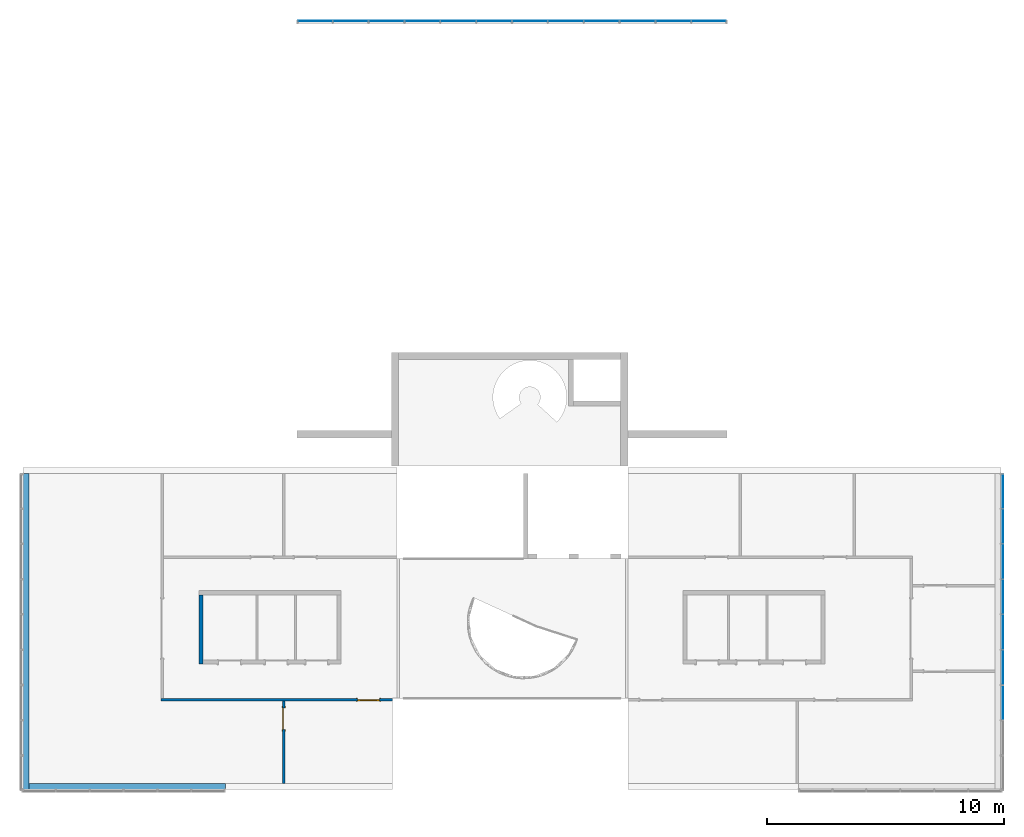
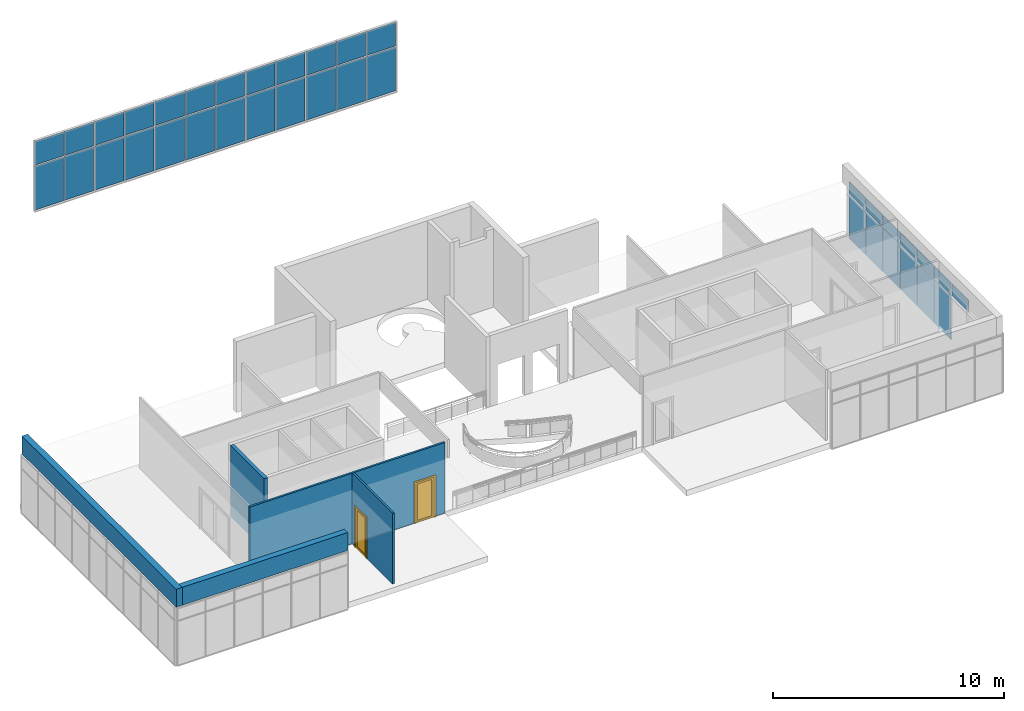
# One storey, part 7 of 11: 37 plates, 5 walls, 2 doors, 2 openings, 2 elements without a shape of their own.
"""IFC2X3 building model written with IfcOpenShell, lengths in millimetres."""

from ifc_helpers import new_model, entity, si_unit, converted_unit, direction, frame, frame_2d, origin, origin_2d_with_axis, place, context, subcontext, project, spatial, polyline, rectangle, outline, extrude, source, transform, mapped, material, material_list, layer, layer_set, layer_usage, type_object, type_shapes, element, fill, aggregate, save


model = new_model("IFC2X3")

# Units and contexts
model_context = context("Model", 3, precision=1e-06, world=origin(), true_north=direction((2.0, 6.12303176911189e-17, 1.0)))
context_of_model = context(None, 3, precision=1e-06, world=origin(), true_north=direction((2.0, 6.12303176911189e-17, 1.0)))
body_context = subcontext(model_context, "Body", "Model", "MODEL_VIEW")
ifc_project = project(units=[si_unit("LENGTHUNIT", "METRE", prefix="MILLI"), si_unit("AREAUNIT", "SQUARE_METRE", prefix="MILLI"), si_unit("VOLUMEUNIT", "CUBIC_METRE", prefix="MILLI"), converted_unit("PLANEANGLEUNIT", "DEGREE", entity("IfcRatioMeasure", 0.0174532925199433), si_unit("PLANEANGLEUNIT", "RADIAN"), dimensions=[0, 0, 0, 0, 0, 0, 0]), si_unit("TIMEUNIT", "SECOND")], contexts=[model_context, context_of_model])

# Site, building, storey
site_placement = place(None, origin())
site = spatial("IfcSite", under=ifc_project, at=site_placement, CompositionType="ELEMENT")
building_placement = place(site_placement, origin())
building = spatial("IfcBuilding", under=site, at=building_placement, CompositionType="ELEMENT")
storey_placement = place(building_placement, frame((0.0, 0.0, 3750.0)))
storey = spatial("IfcBuildingStorey", under=building, at=storey_placement, Name="02. 2 etg.", CompositionType="ELEMENT", Elevation=3750.00000000068)

# Curtain wall, plates
curtain_wall_1_placement = place(storey_placement, origin())
curtain_wall_1 = element("IfcCurtainWall", 1, at=curtain_wall_1_placement, inside=storey, Name="Curtain Wall:Storefront", ObjectType="Curtain Wall:Storefront")
ifc_material_1 = material(Name="Glass")
plate_type_1 = type_object("IfcPlateType", Name="Glazed", PredefinedType="CURTAIN_PANEL")
shared_shape_1 = source(origin(), body_context, "Body", "SweptSolid", [
    extrude(rectangle(XDim=25.0, YDim=1436.66666666667, at=origin_2d_with_axis()), frame((0.0, 37.0, 0.0), z_axis=(0.0, 0.0, 1.0), x_axis=(0.0, 1.0, 0.0)), (0.0, 0.0, 1.0), 2325.0),
])
type_shapes(plate_type_1, [shared_shape_1])
plate_1_placement = place(storey_placement, frame((12127.4511895081, 18980.0, 50.0)))
plate_1 = element("IfcPlate", 2, at=plate_1_placement, type_object=plate_type_1, material=ifc_material_1, Name="Curtain Wall:Storefront", ObjectType="Glazed", context=body_context, shape_type="MappedRepresentation", body=[
    mapped(shared_shape_1, transform((0.0, 0.0, 0.0), scale=1.0)),
])
plate_2_placement = place(storey_placement, frame((28730.7845228414, 18980.0, 50.0)))
plate_2 = element("IfcPlate", 3, at=plate_2_placement, type_object=plate_type_1, material=ifc_material_1, Name="Curtain Wall:Storefront", ObjectType="Glazed", context=body_context, shape_type="MappedRepresentation", body=[
    mapped(shared_shape_1, transform((0.0, 0.0, 0.0), scale=1.0)),
])

curtain_wall_2_placement = place(storey_placement, origin())
curtain_wall_2 = element("IfcCurtainWall", 4, at=curtain_wall_2_placement, inside=storey, Name="Curtain Wall:Storefront", ObjectType="Curtain Wall:Storefront")
placement = place(building_placement, origin())
plate_3_placement = place(placement, frame((41098.2357123495, -2290.0, 3500.0), z_axis=(0.0, 0.0, 1.0), x_axis=(0.0, -1.0, 0.0)))
plate_3 = element("IfcPlate", 5, at=plate_3_placement, type_object=plate_type_1, material=ifc_material_1, Name="Curtain Wall:Storefront", ObjectType="Glazed", context=body_context, shape_type="MappedRepresentation", body=[
    mapped(shared_shape_1, transform((0.0, 0.0, 0.0), scale=1.0)),
])
plate_4_placement = place(placement, frame((41098.2357123495, -3776.66666666667, 3500.0), z_axis=(0.0, 0.0, 1.0), x_axis=(0.0, -1.0, 0.0)))
plate_4 = element("IfcPlate", 6, at=plate_4_placement, type_object=plate_type_1, material=ifc_material_1, Name="Curtain Wall:Storefront", ObjectType="Glazed", context=body_context, shape_type="MappedRepresentation", body=[
    mapped(shared_shape_1, transform((0.0, 0.0, 0.0), scale=1.0)),
])
plate_5_placement = place(placement, frame((41098.2357123495, -5263.33333333333, 3500.0), z_axis=(0.0, 0.0, 1.0), x_axis=(0.0, -1.0, 0.0)))
plate_5 = element("IfcPlate", 7, at=plate_5_placement, type_object=plate_type_1, material=ifc_material_1, Name="Curtain Wall:Storefront", ObjectType="Glazed", context=body_context, shape_type="MappedRepresentation", body=[
    mapped(shared_shape_1, transform((0.0, 0.0, 0.0), scale=1.0)),
])
plate_6_placement = place(placement, frame((41098.2357123495, -6750.0, 3500.0), z_axis=(0.0, 0.0, 1.0), x_axis=(0.0, -1.0, 0.0)))
plate_6 = element("IfcPlate", 8, at=plate_6_placement, type_object=plate_type_1, material=ifc_material_1, Name="Curtain Wall:Storefront", ObjectType="Glazed", context=body_context, shape_type="MappedRepresentation", body=[
    mapped(shared_shape_1, transform((0.0, 0.0, 0.0), scale=1.0)),
])
plate_7_placement = place(placement, frame((41098.2357123495, -8236.66666666667, 3500.0), z_axis=(0.0, 0.0, 1.0), x_axis=(0.0, -1.0, 0.0)))
plate_7 = element("IfcPlate", 9, at=plate_7_placement, type_object=plate_type_1, material=ifc_material_1, Name="Curtain Wall:Storefront", ObjectType="Glazed", context=body_context, shape_type="MappedRepresentation", body=[
    mapped(shared_shape_1, transform((0.0, 0.0, 0.0), scale=1.0)),
])

# Plate
plate_type_2 = type_object("IfcPlateType", Name="Glazed", PredefinedType="CURTAIN_PANEL")
shared_shape_2 = source(origin(), body_context, "Body", "SweptSolid", [
    extrude(rectangle(XDim=25.0, YDim=1461.66666666666, at=origin_2d_with_axis()), frame((0.0, 37.0, 0.0), z_axis=(0.0, 0.0, 1.0), x_axis=(0.0, 1.0, 0.0)), (0.0, 0.0, 1.0), 2325.0),
])
type_shapes(plate_type_2, [shared_shape_2])
plate_8_placement = place(storey_placement, frame((13626.6178561748, 18980.0, 50.0)))
plate_8 = element("IfcPlate", 10, at=plate_8_placement, type_object=plate_type_2, material=ifc_material_1, Name="Curtain Wall:Storefront", ObjectType="Glazed", context=body_context, shape_type="MappedRepresentation", body=[
    mapped(shared_shape_2, transform((0.0, 0.0, 0.0), scale=1.0)),
])

plate_9_placement = place(storey_placement, frame((15138.2845228414, 18980.0, 50.0)))
plate_9 = element("IfcPlate", 11, at=plate_9_placement, type_object=plate_type_2, material=ifc_material_1, Name="Curtain Wall:Storefront", ObjectType="Glazed", context=body_context, shape_type="MappedRepresentation", body=[
    mapped(shared_shape_2, transform((0.0, 0.0, 0.0), scale=1.0)),
])

plate_10_placement = place(storey_placement, frame((16649.9511895081, 18980.0, 50.0)))
plate_10 = element("IfcPlate", 12, at=plate_10_placement, type_object=plate_type_2, material=ifc_material_1, Name="Curtain Wall:Storefront", ObjectType="Glazed", context=body_context, shape_type="MappedRepresentation", body=[
    mapped(shared_shape_2, transform((0.0, 0.0, 0.0), scale=1.0)),
])

plate_11_placement = place(storey_placement, frame((18161.6178561748, 18980.0, 50.0)))
plate_11 = element("IfcPlate", 13, at=plate_11_placement, type_object=plate_type_2, material=ifc_material_1, Name="Curtain Wall:Storefront", ObjectType="Glazed", context=body_context, shape_type="MappedRepresentation", body=[
    mapped(shared_shape_2, transform((0.0, 0.0, 0.0), scale=1.0)),
])

plate_12_placement = place(storey_placement, frame((19673.2845228414, 18980.0, 50.0)))
plate_12 = element("IfcPlate", 14, at=plate_12_placement, type_object=plate_type_2, material=ifc_material_1, Name="Curtain Wall:Storefront", ObjectType="Glazed", context=body_context, shape_type="MappedRepresentation", body=[
    mapped(shared_shape_2, transform((0.0, 0.0, 0.0), scale=1.0)),
])

plate_13_placement = place(storey_placement, frame((21184.9511895081, 18980.0, 50.0)))
plate_13 = element("IfcPlate", 15, at=plate_13_placement, type_object=plate_type_2, material=ifc_material_1, Name="Curtain Wall:Storefront", ObjectType="Glazed", context=body_context, shape_type="MappedRepresentation", body=[
    mapped(shared_shape_2, transform((0.0, 0.0, 0.0), scale=1.0)),
])

plate_14_placement = place(storey_placement, frame((22696.6178561748, 18980.0, 50.0)))
plate_14 = element("IfcPlate", 16, at=plate_14_placement, type_object=plate_type_2, material=ifc_material_1, Name="Curtain Wall:Storefront", ObjectType="Glazed", context=body_context, shape_type="MappedRepresentation", body=[
    mapped(shared_shape_2, transform((0.0, 0.0, 0.0), scale=1.0)),
])

plate_15_placement = place(storey_placement, frame((24208.2845228414, 18980.0, 50.0)))
plate_15 = element("IfcPlate", 17, at=plate_15_placement, type_object=plate_type_2, material=ifc_material_1, Name="Curtain Wall:Storefront", ObjectType="Glazed", context=body_context, shape_type="MappedRepresentation", body=[
    mapped(shared_shape_2, transform((0.0, 0.0, 0.0), scale=1.0)),
])

plate_16_placement = place(storey_placement, frame((25719.9511895081, 18980.0, 50.0)))
plate_16 = element("IfcPlate", 18, at=plate_16_placement, type_object=plate_type_2, material=ifc_material_1, Name="Curtain Wall:Storefront", ObjectType="Glazed", context=body_context, shape_type="MappedRepresentation", body=[
    mapped(shared_shape_2, transform((0.0, 0.0, 0.0), scale=1.0)),
])

plate_17_placement = place(storey_placement, frame((27231.6178561748, 18980.0, 50.0)))
plate_17 = element("IfcPlate", 19, at=plate_17_placement, type_object=plate_type_2, material=ifc_material_1, Name="Curtain Wall:Storefront", ObjectType="Glazed", context=body_context, shape_type="MappedRepresentation", body=[
    mapped(shared_shape_2, transform((0.0, 0.0, 0.0), scale=1.0)),
])

plate_type_3 = type_object("IfcPlateType", Name="Glazed", PredefinedType="CURTAIN_PANEL")
shared_shape_3 = source(origin(), body_context, "Body", "SweptSolid", [
    extrude(rectangle(XDim=25.0, YDim=1436.66666666666, at=origin_2d_with_axis()), frame((0.0, 37.0, 0.0), z_axis=(0.0, 0.0, 1.0), x_axis=(0.0, 1.0, 0.0)), (0.0, 0.0, 1.0), 1274.99999999993),
])
type_shapes(plate_type_3, [shared_shape_3])
plate_18_placement = place(storey_placement, frame((12127.4511895081, 18980.0, 2425.0)))
plate_18 = element("IfcPlate", 20, at=plate_18_placement, type_object=plate_type_3, material=ifc_material_1, Name="Curtain Wall:Storefront", ObjectType="Glazed", context=body_context, shape_type="MappedRepresentation", body=[
    mapped(shared_shape_3, transform((0.0, 0.0, 0.0), scale=1.0)),
])

plate_19_placement = place(storey_placement, frame((28730.7845228414, 18980.0, 2425.0)))
plate_19 = element("IfcPlate", 21, at=plate_19_placement, type_object=plate_type_3, material=ifc_material_1, Name="Curtain Wall:Storefront", ObjectType="Glazed", context=body_context, shape_type="MappedRepresentation", body=[
    mapped(shared_shape_3, transform((0.0, 0.0, 0.0), scale=1.0)),
])

plate_type_4 = type_object("IfcPlateType", Name="Glazed", PredefinedType="CURTAIN_PANEL")
shared_shape_4 = source(origin(), body_context, "Body", "SweptSolid", [
    extrude(rectangle(XDim=25.0, YDim=1461.66666666666, at=origin_2d_with_axis()), frame((0.0, 37.0, 0.0), z_axis=(0.0, 0.0, 1.0), x_axis=(0.0, 1.0, 0.0)), (0.0, 0.0, 1.0), 1274.99999999993),
])
type_shapes(plate_type_4, [shared_shape_4])
plate_20_placement = place(storey_placement, frame((13626.6178561748, 18980.0, 2425.0)))
plate_20 = element("IfcPlate", 22, at=plate_20_placement, type_object=plate_type_4, material=ifc_material_1, Name="Curtain Wall:Storefront", ObjectType="Glazed", context=body_context, shape_type="MappedRepresentation", body=[
    mapped(shared_shape_4, transform((0.0, 0.0, 0.0), scale=1.0)),
])

plate_21_placement = place(storey_placement, frame((15138.2845228414, 18980.0, 2425.0)))
plate_21 = element("IfcPlate", 23, at=plate_21_placement, type_object=plate_type_4, material=ifc_material_1, Name="Curtain Wall:Storefront", ObjectType="Glazed", context=body_context, shape_type="MappedRepresentation", body=[
    mapped(shared_shape_4, transform((0.0, 0.0, 0.0), scale=1.0)),
])

plate_22_placement = place(storey_placement, frame((16649.9511895081, 18980.0, 2425.0)))
plate_22 = element("IfcPlate", 24, at=plate_22_placement, type_object=plate_type_4, material=ifc_material_1, Name="Curtain Wall:Storefront", ObjectType="Glazed", context=body_context, shape_type="MappedRepresentation", body=[
    mapped(shared_shape_4, transform((0.0, 0.0, 0.0), scale=1.0)),
])

plate_23_placement = place(storey_placement, frame((18161.6178561748, 18980.0, 2425.0)))
plate_23 = element("IfcPlate", 25, at=plate_23_placement, type_object=plate_type_4, material=ifc_material_1, Name="Curtain Wall:Storefront", ObjectType="Glazed", context=body_context, shape_type="MappedRepresentation", body=[
    mapped(shared_shape_4, transform((0.0, 0.0, 0.0), scale=1.0)),
])

plate_24_placement = place(storey_placement, frame((19673.2845228414, 18980.0, 2425.0)))
plate_24 = element("IfcPlate", 26, at=plate_24_placement, type_object=plate_type_4, material=ifc_material_1, Name="Curtain Wall:Storefront", ObjectType="Glazed", context=body_context, shape_type="MappedRepresentation", body=[
    mapped(shared_shape_4, transform((0.0, 0.0, 0.0), scale=1.0)),
])

plate_25_placement = place(storey_placement, frame((21184.9511895081, 18980.0, 2425.0)))
plate_25 = element("IfcPlate", 27, at=plate_25_placement, type_object=plate_type_4, material=ifc_material_1, Name="Curtain Wall:Storefront", ObjectType="Glazed", context=body_context, shape_type="MappedRepresentation", body=[
    mapped(shared_shape_4, transform((0.0, 0.0, 0.0), scale=1.0)),
])

plate_26_placement = place(storey_placement, frame((22696.6178561748, 18980.0, 2425.0)))
plate_26 = element("IfcPlate", 28, at=plate_26_placement, type_object=plate_type_4, material=ifc_material_1, Name="Curtain Wall:Storefront", ObjectType="Glazed", context=body_context, shape_type="MappedRepresentation", body=[
    mapped(shared_shape_4, transform((0.0, 0.0, 0.0), scale=1.0)),
])

plate_27_placement = place(storey_placement, frame((24208.2845228414, 18980.0, 2425.0)))
plate_27 = element("IfcPlate", 29, at=plate_27_placement, type_object=plate_type_4, material=ifc_material_1, Name="Curtain Wall:Storefront", ObjectType="Glazed", context=body_context, shape_type="MappedRepresentation", body=[
    mapped(shared_shape_4, transform((0.0, 0.0, 0.0), scale=1.0)),
])

plate_28_placement = place(storey_placement, frame((25719.9511895081, 18980.0, 2425.0)))
plate_28 = element("IfcPlate", 30, at=plate_28_placement, type_object=plate_type_4, material=ifc_material_1, Name="Curtain Wall:Storefront", ObjectType="Glazed", context=body_context, shape_type="MappedRepresentation", body=[
    mapped(shared_shape_4, transform((0.0, 0.0, 0.0), scale=1.0)),
])

plate_29_placement = place(storey_placement, frame((27231.6178561748, 18980.0, 2425.0)))
plate_29 = element("IfcPlate", 31, at=plate_29_placement, type_object=plate_type_4, material=ifc_material_1, Name="Curtain Wall:Storefront", ObjectType="Glazed", context=body_context, shape_type="MappedRepresentation", body=[
    mapped(shared_shape_4, transform((0.0, 0.0, 0.0), scale=1.0)),
])

aggregate(curtain_wall_1, [plate_1, plate_8, plate_9, plate_10, plate_11, plate_12, plate_13, plate_14, plate_15, plate_16, plate_17, plate_2, plate_18, plate_20, plate_21, plate_22, plate_23, plate_24, plate_25, plate_26, plate_27, plate_28, plate_29, plate_19])

plate_type_5 = type_object("IfcPlateType", Name="Glazed", PredefinedType="CURTAIN_PANEL")
shared_shape_5 = source(origin(), body_context, "Body", "SweptSolid", [
    extrude(rectangle(XDim=25.0, YDim=1411.66666666667, at=origin_2d_with_axis()), frame((0.0, 37.0, 0.0), z_axis=(0.0, 0.0, 1.0), x_axis=(0.0, 1.0, 0.0)), (0.0, 0.0, 1.0), 2325.0),
])
type_shapes(plate_type_5, [shared_shape_5])
plate_30_placement = place(placement, frame((41098.2357123495, -815.833333333333, 3500.0), z_axis=(0.0, 0.0, 1.0), x_axis=(0.0, -1.0, 0.0)))
plate_30 = element("IfcPlate", 32, at=plate_30_placement, type_object=plate_type_5, material=ifc_material_1, Name="Curtain Wall:Storefront", ObjectType="Glazed", context=body_context, shape_type="MappedRepresentation", body=[
    mapped(shared_shape_5, transform((0.0, 0.0, 0.0), scale=1.0)),
])

plate_type_6 = type_object("IfcPlateType", Name="Glazed", PredefinedType="CURTAIN_PANEL")
shared_shape_6 = source(origin(), body_context, "Body", "SweptSolid", [
    extrude(rectangle(XDim=25.0, YDim=1411.66666666667, at=origin_2d_with_axis()), frame((0.0, 37.0, 0.0), z_axis=(0.0, 0.0, 1.0), x_axis=(0.0, 1.0, 0.0)), (0.0, 0.0, 1.0), 625.000000000002),
])
type_shapes(plate_type_6, [shared_shape_6])
plate_31_placement = place(storey_placement, frame((41098.2357123495, -815.833333333332, 2125.0), z_axis=(0.0, 0.0, 1.0), x_axis=(0.0, -1.0, 0.0)))
plate_31 = element("IfcPlate", 33, at=plate_31_placement, type_object=plate_type_6, material=ifc_material_1, Name="Curtain Wall:Storefront", ObjectType="Glazed", context=body_context, shape_type="MappedRepresentation", body=[
    mapped(shared_shape_6, transform((0.0, 0.0, 0.0), scale=1.0)),
])

plate_type_7 = type_object("IfcPlateType", Name="Glazed", PredefinedType="CURTAIN_PANEL")
shared_shape_7 = source(origin(), body_context, "Body", "SweptSolid", [
    extrude(rectangle(XDim=25.0, YDim=1436.66666666667, at=origin_2d_with_axis()), frame((0.0, 37.0, 0.0), z_axis=(0.0, 0.0, 1.0), x_axis=(0.0, 1.0, 0.0)), (0.0, 0.0, 1.0), 625.000000000002),
])
type_shapes(plate_type_7, [shared_shape_7])
plate_32_placement = place(storey_placement, frame((41098.2357123495, -2290.0, 2125.0), z_axis=(0.0, 0.0, 1.0), x_axis=(0.0, -1.0, 0.0)))
plate_32 = element("IfcPlate", 34, at=plate_32_placement, type_object=plate_type_7, material=ifc_material_1, Name="Curtain Wall:Storefront", ObjectType="Glazed", context=body_context, shape_type="MappedRepresentation", body=[
    mapped(shared_shape_7, transform((0.0, 0.0, 0.0), scale=1.0)),
])

plate_33_placement = place(storey_placement, frame((41098.2357123495, -3776.66666666667, 2125.0), z_axis=(0.0, 0.0, 1.0), x_axis=(0.0, -1.0, 0.0)))
plate_33 = element("IfcPlate", 35, at=plate_33_placement, type_object=plate_type_7, material=ifc_material_1, Name="Curtain Wall:Storefront", ObjectType="Glazed", context=body_context, shape_type="MappedRepresentation", body=[
    mapped(shared_shape_7, transform((0.0, 0.0, 0.0), scale=1.0)),
])

plate_34_placement = place(storey_placement, frame((41098.2357123495, -5263.33333333333, 2125.0), z_axis=(0.0, 0.0, 1.0), x_axis=(0.0, -1.0, 0.0)))
plate_34 = element("IfcPlate", 36, at=plate_34_placement, type_object=plate_type_7, material=ifc_material_1, Name="Curtain Wall:Storefront", ObjectType="Glazed", context=body_context, shape_type="MappedRepresentation", body=[
    mapped(shared_shape_7, transform((0.0, 0.0, 0.0), scale=1.0)),
])

plate_35_placement = place(storey_placement, frame((41098.2357123495, -6750.0, 2125.0), z_axis=(0.0, 0.0, 1.0), x_axis=(0.0, -1.0, 0.0)))
plate_35 = element("IfcPlate", 37, at=plate_35_placement, type_object=plate_type_7, material=ifc_material_1, Name="Curtain Wall:Storefront", ObjectType="Glazed", context=body_context, shape_type="MappedRepresentation", body=[
    mapped(shared_shape_7, transform((0.0, 0.0, 0.0), scale=1.0)),
])

plate_36_placement = place(storey_placement, frame((41098.2357123495, -8236.66666666667, 2125.0), z_axis=(0.0, 0.0, 1.0), x_axis=(0.0, -1.0, 0.0)))
plate_36 = element("IfcPlate", 38, at=plate_36_placement, type_object=plate_type_7, material=ifc_material_1, Name="Curtain Wall:Storefront", ObjectType="Glazed", context=body_context, shape_type="MappedRepresentation", body=[
    mapped(shared_shape_7, transform((0.0, 0.0, 0.0), scale=1.0)),
])

plate_37_placement = place(storey_placement, frame((41098.2357123495, -9723.33333333333, 2125.0), z_axis=(0.0, 0.0, 1.0), x_axis=(0.0, -1.0, 0.0)))
plate_37 = element("IfcPlate", 39, at=plate_37_placement, type_object=plate_type_7, material=ifc_material_1, Name="Curtain Wall:Storefront", ObjectType="Glazed", context=body_context, shape_type="MappedRepresentation", body=[
    mapped(shared_shape_7, transform((0.0, 0.0, 0.0), scale=1.0)),
])

aggregate(curtain_wall_2, [plate_30, plate_3, plate_4, plate_5, plate_6, plate_7, plate_31, plate_32, plate_33, plate_34, plate_35, plate_36, plate_37])

# Wall, opening, door
ifc_material_2 = material(Name="Steel, Paint Finish, Ivory, Matte")
ifc_layer_1 = layer(ifc_material_2, 100.0)
ifc_layer_set_1 = layer_set([ifc_layer_1], Name="Basic Wall:_100mm")
ifc_layer_usage_1 = layer_usage(ifc_layer_set_1, "AXIS2", "NEGATIVE", 50.0)
wall_1_placement = place(storey_placement, frame((10800.0, -13140.0, 0.0), z_axis=(0.0, 0.0, 1.0), x_axis=(0.0, 1.0, 0.0)))
wall_1 = element("IfcWallStandardCase", 40, at=wall_1_placement, inside=storey, material=ifc_layer_usage_1, Name="Basic Wall:_100mm", ObjectType="Basic Wall:_100mm", context=body_context, shape_type="SweptSolid", body=[
    extrude(rectangle(XDim=3490.00000000005, YDim=99.9999999999989, at=frame_2d((1745.00000000002, 0.0), x_axis=(-1.0, 0.0))), origin(), (0.0, 0.0, 1.0), 3750.0),
])
opening_1_placement = place(wall_1_placement, frame((2275.0, -50.0, 0.0)))
opening_1 = element("IfcOpeningElement", 41, at=opening_1_placement, cuts=wall_1, Name="M_Single-Glass 1:0915 x 2134mm:0915 x 2134mm:1", ObjectType="Opening", context=body_context, shape_type="SweptSolid", body=[
    extrude(rectangle(XDim=914.999999999999, YDim=2134.0, at=frame_2d((1067.0, 457.5), x_axis=(0.0, 1.0))), frame((0.0, 0.0, 0.0), z_axis=(0.0, 1.0, 0.0), x_axis=(0.0, 0.0, 1.0)), (0.0, 0.0, 1.0), 100.0),
])
ifc_material_3 = material(Name="Stainless Steel")
ifc_material_list_1 = material_list([ifc_material_3, ifc_material_1])
door_style_1 = type_object("IfcDoorStyle", Name="0915 x 2134mm", ConstructionType="NOTDEFINED", OperationType="SINGLE_SWING_RIGHT", ParameterTakesPrecedence=False, Sizeable=False)
shared_shape_8 = source(origin(), body_context, "Body", "SweptSolid", [
    extrude(outline(polyline([(-457.500000000003, -1048.0), (-457.500000000003, 1086.0), (-533.499999999999, 1086.0), (-533.499999999999, -1124.0), (533.500000000001, -1124.0), (533.500000000001, 1086.0), (457.500000000001, 1086.0), (457.500000000001, -1048.0), (-457.500000000003, -1048.0)])), frame((457.500000000001, -25.0, 1086.0), z_axis=(0.0, -1.0, 0.0), x_axis=(-1.0, 0.0, 0.0)), (0.0, 0.0, -1.0), 25.0),
    extrude(outline(polyline([(-457.500000000001, -1048.0), (-457.500000000001, 1086.0), (-533.499999999997, 1086.0), (-533.499999999997, -1124.0), (533.499999999999, -1124.0), (533.499999999999, 1086.0), (457.499999999999, 1086.0), (457.499999999999, -1048.0), (-457.500000000001, -1048.0)])), frame((457.499999999999, 100.0, 1086.0), z_axis=(0.0, -1.0, 0.0), x_axis=(-1.0, 0.0, 0.0)), (0.0, 0.0, -1.0), 25.0000000000156),
    extrude(rectangle(XDim=6.35, YDim=711.0, at=frame_2d((-4.21884749357559e-15, 0.0), x_axis=(1.0, 0.0))), frame((457.5, 74.6000000000039, 102.0), z_axis=(0.0, 0.0, 1.0), x_axis=(0.0, 1.0, 0.0)), (0.0, 0.0, 1.0), 1930.0),
    extrude(outline(polyline([(-1067.0, -457.499999999998), (1067.0, -457.499999999998), (1067.0, 457.499999999998), (-1067.0, 457.499999999998), (-1067.0, -457.499999999998)]), holes=[polyline([(-965.0, 355.499999999998), (965.0, 355.499999999998), (965.0, -355.500000000002), (-965.0, -355.500000000002), (-965.0, 355.499999999998)])]), frame((457.499999999998, 49.0, 1067.0), z_axis=(0.0, 1.0, 0.0), x_axis=(0.0, 0.0, -1.0)), (0.0, 0.0, 1.0), 51.0),
])
type_shapes(door_style_1, [shared_shape_8])
door_1_placement = place(opening_1_placement, origin())
door_1 = element("IfcDoor", 42, at=door_1_placement, inside=storey, type_object=door_style_1, material=ifc_material_list_1, Name="M_Single-Glass 1:0915 x 2134mm:0915 x 2134mm", ObjectType="0915 x 2134mm", OverallHeight=2134.0, OverallWidth=915.0, context=body_context, shape_type="MappedRepresentation", body=[
    mapped(shared_shape_8, transform((0.0, 0.0, 0.0), scale=1.0)),
])
fill(opening_1, door_1)

ifc_layer_usage_2 = layer_usage(ifc_layer_set_1, "AXIS2", "NEGATIVE", 50.0)
wall_2_placement = place(storey_placement, frame((15394.0, -9600.0, 0.0), z_axis=(0.0, 0.0, 1.0), x_axis=(-1.0, 0.0, 0.0)))
wall_2 = element("IfcWallStandardCase", 43, at=wall_2_placement, inside=storey, material=ifc_layer_usage_2, Name="Basic Wall:_100mm", ObjectType="Basic Wall:_100mm", context=body_context, shape_type="SweptSolid", body=[
    extrude(rectangle(XDim=9764.88214382529, YDim=99.9999999999989, at=frame_2d((4882.44107191264, -3.58824081558851e-13), x_axis=(-1.0, 0.0))), origin(), (0.0, 0.0, 1.0), 3750.0),
])
opening_2_placement = place(wall_2_placement, frame((554.0, -50.0, 0.0)))
opening_2 = element("IfcOpeningElement", 44, at=opening_2_placement, cuts=wall_2, Name="M_Single-Glass 1:0915 x 2134mm:0915 x 2134mm:1", ObjectType="Opening", context=body_context, shape_type="SweptSolid", body=[
    extrude(rectangle(XDim=914.999999999999, YDim=2134.0, at=frame_2d((1067.0, 457.5), x_axis=(0.0, -1.0))), frame((0.0, 0.0, 0.0), z_axis=(0.0, 1.0, 0.0), x_axis=(0.0, 0.0, 1.0)), (0.0, 0.0, 1.0), 100.0),
])
ifc_material_list_2 = material_list([ifc_material_3, ifc_material_1])
door_style_2 = type_object("IfcDoorStyle", Name="0915 x 2134mm", ConstructionType="NOTDEFINED", OperationType="SINGLE_SWING_LEFT", ParameterTakesPrecedence=False, Sizeable=False)
shared_shape_9 = source(origin(), body_context, "Body", "SweptSolid", [
    extrude(outline(polyline([(-457.500000000003, -1048.0), (-457.500000000003, 1086.0), (-533.499999999999, 1086.0), (-533.499999999999, -1124.0), (533.500000000001, -1124.0), (533.500000000001, 1086.0), (457.500000000001, 1086.0), (457.500000000001, -1048.0), (-457.500000000003, -1048.0)])), frame((457.499999999999, 0.0, 1086.0), z_axis=(0.0, 1.0, 0.0), x_axis=(1.0, 0.0, 0.0)), (0.0, 0.0, -1.0), 25.0),
    extrude(outline(polyline([(-457.500000000001, -1048.0), (-457.500000000001, 1086.0), (-533.499999999997, 1086.0), (-533.499999999997, -1124.0), (533.499999999999, -1124.0), (533.499999999999, 1086.0), (457.499999999999, 1086.0), (457.499999999999, -1048.0), (-457.500000000001, -1048.0)])), frame((457.500000000001, 125.0, 1086.0), z_axis=(0.0, 1.0, 0.0), x_axis=(1.0, 0.0, 0.0)), (0.0, 0.0, -1.0), 25.0000000000156),
    extrude(rectangle(XDim=711.0, YDim=6.35, at=origin_2d_with_axis()), frame((457.5, 74.6000000000257, 102.0)), (0.0, 0.0, 1.0), 1930.0),
    extrude(outline(polyline([(-1067.0, -457.499999999998), (1067.0, -457.499999999998), (1067.0, 457.499999999998), (-1067.0, 457.499999999998), (-1067.0, -457.499999999998)]), holes=[polyline([(-965.0, 355.499999999998), (965.0, 355.499999999998), (965.0, -355.500000000002), (-965.0, -355.500000000002), (-965.0, 355.499999999998)])]), frame((457.500000000002, 100.0, 1067.0), z_axis=(0.0, -1.0, 0.0), x_axis=(0.0, 0.0, -1.0)), (0.0, 0.0, 1.0), 51.0),
])
type_shapes(door_style_2, [shared_shape_9])
door_2_placement = place(opening_2_placement, origin())
door_2 = element("IfcDoor", 45, at=door_2_placement, inside=storey, type_object=door_style_2, material=ifc_material_list_2, Name="M_Single-Glass 1:0915 x 2134mm:0915 x 2134mm", ObjectType="0915 x 2134mm", OverallHeight=2134.0, OverallWidth=915.0, context=body_context, shape_type="MappedRepresentation", body=[
    mapped(shared_shape_9, transform((0.0, 0.0, 0.0), scale=1.0)),
])
fill(opening_2, door_2)

# Walls
ifc_layer_2 = layer(ifc_material_2, 180.0)
ifc_layer_set_2 = layer_set([ifc_layer_2], Name="Basic Wall:_180mm")
ifc_layer_usage_3 = layer_usage(ifc_layer_set_2, "AXIS2", "NEGATIVE", 90.0)
wall_3_placement = place(storey_placement, frame((7319.11785617473, -8106.65631369453, 0.0), z_axis=(0.0, 0.0, 1.0), x_axis=(0.0, 1.0, 0.0)))
element("IfcWallStandardCase", 46, at=wall_3_placement, inside=storey, material=ifc_layer_usage_3, Name="Basic Wall:_180mm", ObjectType="Basic Wall:_180mm", context=body_context, shape_type="SweptSolid", body=[
    extrude(rectangle(XDim=2920.0, YDim=180.0, at=frame_2d((1460.0, 0.0), x_axis=(-1.0, 0.0))), origin(), (0.0, 0.0, 1.0), 3750.0),
])
ifc_material_4 = material(Name="Brick, Engineering, Soldier Course")
ifc_layer_3 = layer(ifc_material_4, 300.0)
ifc_layer_set_3 = layer_set([ifc_layer_3], Name="Basic Wall:Generic - 300mm")
ifc_layer_usage_4 = layer_usage(ifc_layer_set_3, "AXIS2", "POSITIVE", -150.0)
wall_4_placement = place(storey_placement, frame((-90.0, -60.0, 2800.0), z_axis=(0.0, 0.0, 1.0), x_axis=(0.0, -1.0, 0.0)))
element("IfcWallStandardCase", 47, at=wall_4_placement, inside=storey, material=ifc_layer_usage_4, Name="Basic Wall:Generic - 300mm", ObjectType="Basic Wall:Generic - 300mm:6291", context=body_context, shape_type="SweptSolid", body=[
    extrude(rectangle(XDim=13380.0000000001, YDim=300.0, at=frame_2d((6690.00000000003, -1.4210854715202e-14), x_axis=(-1.0, 0.0))), origin(), (0.0, 0.0, 1.0), 949.999999999925),
])
ifc_layer_usage_5 = layer_usage(ifc_layer_set_3, "AXIS2", "POSITIVE", -150.0)
wall_5_placement = place(storey_placement, frame((8340.0, -13290.0, 2800.0), z_axis=(0.0, 0.0, 1.0), x_axis=(-1.0, 0.0, 0.0)))
element("IfcWallStandardCase", 48, at=wall_5_placement, inside=storey, material=ifc_layer_usage_5, Name="Basic Wall:Generic - 300mm", ObjectType="Basic Wall:Generic - 300mm:6291", context=body_context, shape_type="SweptSolid", body=[
    extrude(rectangle(XDim=8280.00000000003, YDim=300.000000000001, at=frame_2d((4140.00000000001, 1.98951966012828e-13), x_axis=(-1.0, 0.0))), origin(), (0.0, 0.0, 1.0), 949.999999999925),
])

save(model, "model.ifc")
